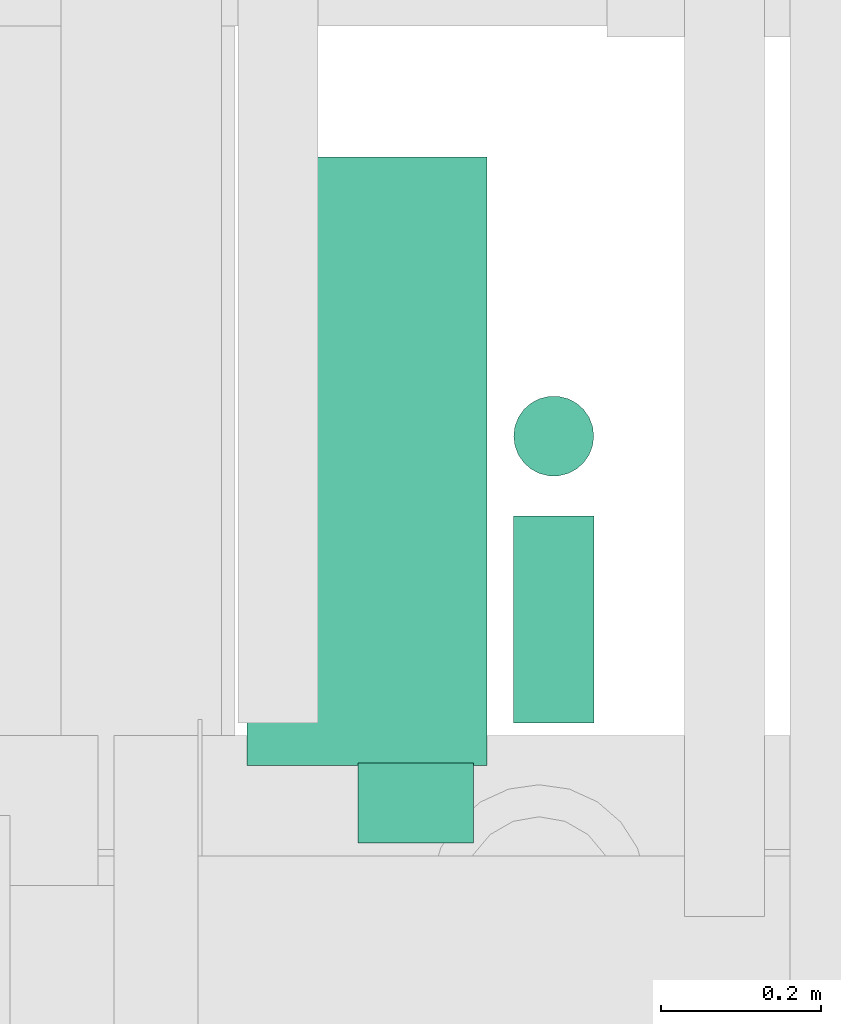
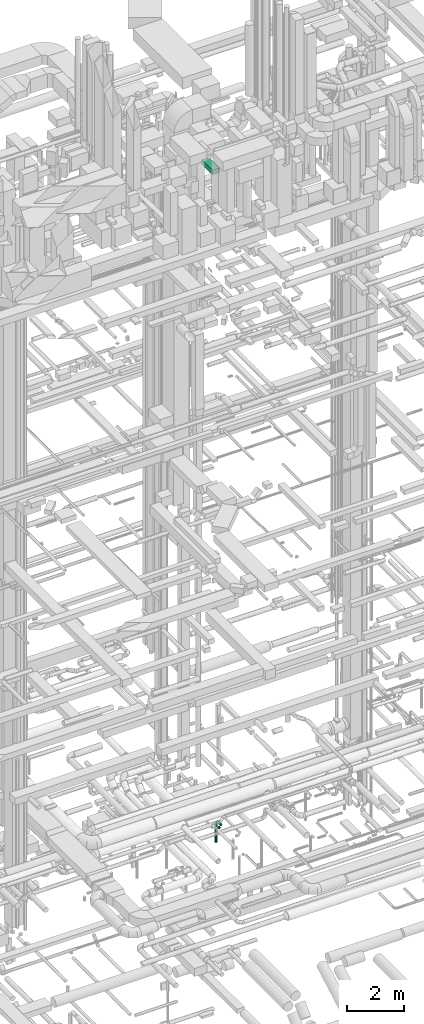
# One storey, part 245 of 337: 4 flow segments.
"""IFC2X3 building model written with IfcOpenShell, lengths in millimetres."""

from ifc_helpers import new_model, entity, si_unit, converted_unit, derived_unit, direction, frame, origin, origin_2d_with_axis, place, context, subcontext, project, spatial, rectangle, circle, extrude, type_object, element, save


model = new_model("IFC2X3")

# Units and contexts
model_context = context("Model", 3, precision=0.01, world=origin(), true_north=direction((6.12303176911189e-17, 1.0)))
body_context = subcontext(model_context, "Body", "Model", "MODEL_VIEW")
ifc_project = project(units=[si_unit("LENGTHUNIT", "METRE", prefix="MILLI"), si_unit("AREAUNIT", "SQUARE_METRE"), si_unit("VOLUMEUNIT", "CUBIC_METRE"), converted_unit("PLANEANGLEUNIT", "DEGREE", entity("IfcRatioMeasure", 0.0174532925199433), si_unit("PLANEANGLEUNIT", "RADIAN"), dimensions=[0, 0, 0, 0, 0, 0, 0]), si_unit("MASSUNIT", "GRAM", prefix="KILO"), derived_unit("MASSDENSITYUNIT", [(si_unit("MASSUNIT", "GRAM", prefix="KILO"), 1), (si_unit("LENGTHUNIT", "METRE"), -3)]), derived_unit("MOMENTOFINERTIAUNIT", [(si_unit("LENGTHUNIT", "METRE"), 4)]), si_unit("TIMEUNIT", "SECOND"), si_unit("FREQUENCYUNIT", "HERTZ"), si_unit("THERMODYNAMICTEMPERATUREUNIT", "DEGREE_CELSIUS"), derived_unit("THERMALTRANSMITTANCEUNIT", [(si_unit("MASSUNIT", "GRAM", prefix="KILO"), 1), (si_unit("THERMODYNAMICTEMPERATUREUNIT", "KELVIN"), -1), (si_unit("TIMEUNIT", "SECOND"), -3)]), derived_unit("VOLUMETRICFLOWRATEUNIT", [(si_unit("LENGTHUNIT", "METRE"), 3), (si_unit("TIMEUNIT", "SECOND"), -1)]), derived_unit("MASSFLOWRATEUNIT", [(si_unit("MASSUNIT", "GRAM", prefix="KILO"), 1), (si_unit("TIMEUNIT", "SECOND"), -1)]), derived_unit("ROTATIONALFREQUENCYUNIT", [(si_unit("TIMEUNIT", "SECOND"), -1)]), si_unit("ELECTRICCURRENTUNIT", "AMPERE"), si_unit("ELECTRICVOLTAGEUNIT", "VOLT"), si_unit("POWERUNIT", "WATT"), si_unit("FORCEUNIT", "NEWTON", prefix="KILO"), si_unit("ILLUMINANCEUNIT", "LUX"), si_unit("LUMINOUSFLUXUNIT", "LUMEN"), si_unit("LUMINOUSINTENSITYUNIT", "CANDELA"), derived_unit("USERDEFINED", [(si_unit("MASSUNIT", "GRAM", prefix="KILO"), -1), (si_unit("LENGTHUNIT", "METRE"), -2), (si_unit("TIMEUNIT", "SECOND"), 3), (si_unit("LUMINOUSFLUXUNIT", "LUMEN"), 1)]), derived_unit("LINEARVELOCITYUNIT", [(si_unit("LENGTHUNIT", "METRE"), 1), (si_unit("TIMEUNIT", "SECOND"), -1)]), si_unit("PRESSUREUNIT", "PASCAL"), derived_unit("USERDEFINED", [(si_unit("LENGTHUNIT", "METRE"), -2), (si_unit("MASSUNIT", "GRAM", prefix="KILO"), 1), (si_unit("TIMEUNIT", "SECOND"), -2)]), derived_unit("LINEARFORCEUNIT", [(si_unit("MASSUNIT", "GRAM", prefix="KILO"), 1), (si_unit("LENGTHUNIT", "METRE"), 1), (si_unit("TIMEUNIT", "SECOND"), -2), (si_unit("LENGTHUNIT", "METRE"), -1)]), derived_unit("PLANARFORCEUNIT", [(si_unit("MASSUNIT", "GRAM", prefix="KILO"), 1), (si_unit("LENGTHUNIT", "METRE"), 1), (si_unit("TIMEUNIT", "SECOND"), -2), (si_unit("LENGTHUNIT", "METRE"), -2)])], contexts=[model_context])

# Site, building, storey
site_placement = place(None, origin())
site = spatial("IfcSite", under=ifc_project, at=site_placement, CompositionType="ELEMENT")
building_placement = place(site_placement, origin())
building = spatial("IfcBuilding", under=site, at=building_placement, CompositionType="ELEMENT")
storey_placement = place(building_placement, origin())
storey = spatial("IfcBuildingStorey", under=building, at=storey_placement, CompositionType="ELEMENT", Elevation=0.0)

# Flow segments
duct_segment_type_1 = type_object("IfcDuctSegmentType", PredefinedType="NOTDEFINED")
flow_segment_1_placement = place(storey_placement, frame((54285.82, 13152.02, 27300.0)))
element("IfcFlowSegment", 1, at=flow_segment_1_placement, inside=storey, type_object=duct_segment_type_1, context=body_context, shape_type="SweptSolid", body=[
    extrude(rectangle(XDim=760.000000000022, YDim=300.000000000001, at=origin_2d_with_axis()), frame((150.0, 380.0, 0.0), z_axis=(0.0, 0.0, 1.0), x_axis=(0.0, 1.0, 0.0)), (0.0, 0.0, 1.0), 199.999999999998),
])
duct_segment_type_2 = type_object("IfcDuctSegmentType", PredefinedType="NOTDEFINED")
flow_segment_2_placement = place(storey_placement, frame((54424.51, 13053.92, -901.6)))
element("IfcFlowSegment", 2, at=flow_segment_2_placement, inside=storey, type_object=duct_segment_type_2, context=body_context, shape_type="SweptSolid", body=[
    extrude(circle(Radius=50.0, at=origin_2d_with_axis()), frame((0.0, 51.6, 51.6), z_axis=(1.0, 0.0, 0.0), x_axis=(0.0, -1.0, 0.0)), (0.0, 0.0, 1.0), 144.668369999995),
])
flow_segment_3_placement = place(storey_placement, frame((54617.58, 13205.52, -901.6)))
element("IfcFlowSegment", 3, at=flow_segment_3_placement, inside=storey, type_object=duct_segment_type_2, context=body_context, shape_type="SweptSolid", body=[
    extrude(circle(Radius=50.0, at=origin_2d_with_axis()), frame((51.6, 0.0, 51.6), z_axis=(0.0, 1.0, 0.0), x_axis=(1.0, 0.0, 0.0)), (0.0, 0.0, 1.0), 258.03898),
])
flow_segment_4_placement = place(storey_placement, frame((54617.58, 13511.96, -1800.0)))
element("IfcFlowSegment", 4, at=flow_segment_4_placement, inside=storey, type_object=duct_segment_type_2, context=body_context, shape_type="SweptSolid", body=[
    extrude(circle(Radius=50.0, at=origin_2d_with_axis()), frame((51.6, 51.6, 0.0), z_axis=(0.0, 0.0, 1.0), x_axis=(-1.0, 0.0, 0.0)), (0.0, 0.0, 1.0), 849.999999999996),
])

save(model, "model.ifc")
